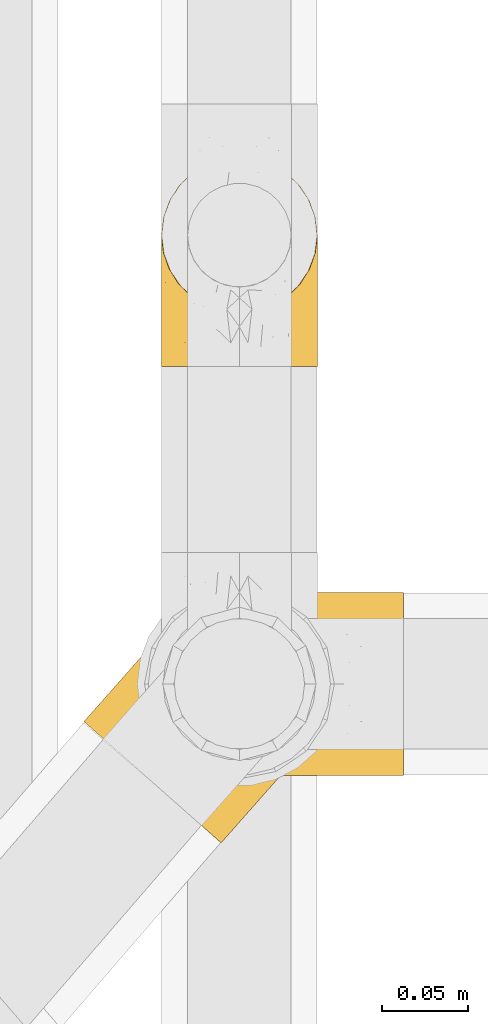
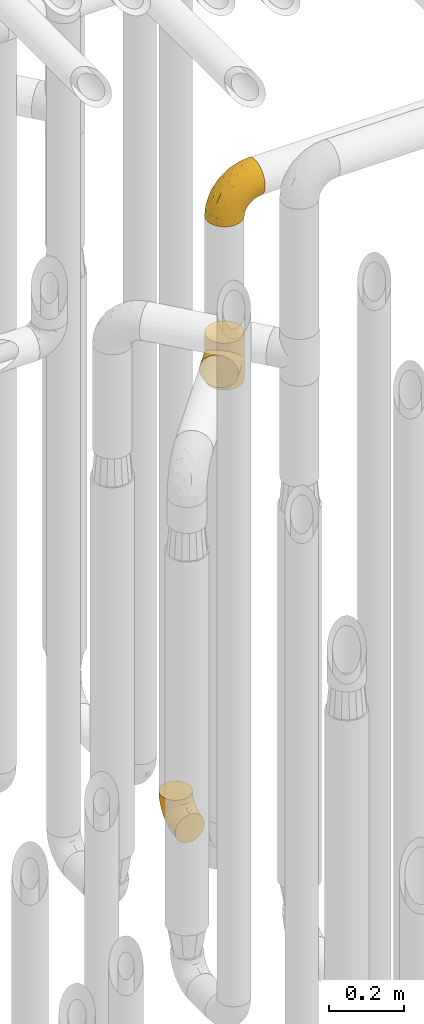
# One storey, part 219 of 827: 3 coverings.
"""IFC2X3 building model written with IfcOpenShell, lengths in millimetres."""

from ifc_helpers import new_model, entity, si_unit, converted_unit, derived_unit, direction, frame, origin, place, context, subcontext, project, spatial, faceted_brep, element, save


model = new_model("IFC2X3")

# Units and contexts
model_context = context("Model", 3, precision=0.01, world=origin(), true_north=direction((6.12303176911189e-17, 1.0)))
body_context = subcontext(model_context, "Body", "Model", "MODEL_VIEW")
ifc_project = project(units=[si_unit("LENGTHUNIT", "METRE", prefix="MILLI"), si_unit("AREAUNIT", "SQUARE_METRE"), si_unit("VOLUMEUNIT", "CUBIC_METRE"), converted_unit("PLANEANGLEUNIT", "DEGREE", entity("IfcRatioMeasure", 0.0174532925199433), si_unit("PLANEANGLEUNIT", "RADIAN"), dimensions=[0, 0, 0, 0, 0, 0, 0]), si_unit("MASSUNIT", "GRAM", prefix="KILO"), derived_unit("MASSDENSITYUNIT", [(si_unit("MASSUNIT", "GRAM", prefix="KILO"), 1), (si_unit("LENGTHUNIT", "METRE"), -3)]), derived_unit("MOMENTOFINERTIAUNIT", [(si_unit("LENGTHUNIT", "METRE"), 4)]), si_unit("TIMEUNIT", "SECOND"), si_unit("FREQUENCYUNIT", "HERTZ"), si_unit("THERMODYNAMICTEMPERATUREUNIT", "DEGREE_CELSIUS"), derived_unit("THERMALTRANSMITTANCEUNIT", [(si_unit("MASSUNIT", "GRAM", prefix="KILO"), 1), (si_unit("THERMODYNAMICTEMPERATUREUNIT", "KELVIN"), -1), (si_unit("TIMEUNIT", "SECOND"), -3)]), derived_unit("VOLUMETRICFLOWRATEUNIT", [(si_unit("LENGTHUNIT", "METRE"), 3), (si_unit("TIMEUNIT", "SECOND"), -1)]), derived_unit("MASSFLOWRATEUNIT", [(si_unit("MASSUNIT", "GRAM", prefix="KILO"), 1), (si_unit("TIMEUNIT", "SECOND"), -1)]), derived_unit("ROTATIONALFREQUENCYUNIT", [(si_unit("TIMEUNIT", "SECOND"), -1)]), si_unit("ELECTRICCURRENTUNIT", "AMPERE"), si_unit("ELECTRICVOLTAGEUNIT", "VOLT"), si_unit("POWERUNIT", "WATT"), si_unit("FORCEUNIT", "NEWTON", prefix="KILO"), si_unit("ILLUMINANCEUNIT", "LUX"), si_unit("LUMINOUSFLUXUNIT", "LUMEN"), si_unit("LUMINOUSINTENSITYUNIT", "CANDELA"), derived_unit("USERDEFINED", [(si_unit("MASSUNIT", "GRAM", prefix="KILO"), -1), (si_unit("LENGTHUNIT", "METRE"), -2), (si_unit("TIMEUNIT", "SECOND"), 3), (si_unit("LUMINOUSFLUXUNIT", "LUMEN"), 1)]), derived_unit("LINEARVELOCITYUNIT", [(si_unit("LENGTHUNIT", "METRE"), 1), (si_unit("TIMEUNIT", "SECOND"), -1)]), si_unit("PRESSUREUNIT", "PASCAL"), derived_unit("USERDEFINED", [(si_unit("LENGTHUNIT", "METRE"), -2), (si_unit("MASSUNIT", "GRAM", prefix="KILO"), 1), (si_unit("TIMEUNIT", "SECOND"), -2)]), derived_unit("LINEARFORCEUNIT", [(si_unit("MASSUNIT", "GRAM", prefix="KILO"), 1), (si_unit("LENGTHUNIT", "METRE"), 1), (si_unit("TIMEUNIT", "SECOND"), -2), (si_unit("LENGTHUNIT", "METRE"), -1)]), derived_unit("PLANARFORCEUNIT", [(si_unit("MASSUNIT", "GRAM", prefix="KILO"), 1), (si_unit("LENGTHUNIT", "METRE"), 1), (si_unit("TIMEUNIT", "SECOND"), -2), (si_unit("LENGTHUNIT", "METRE"), -2)])], contexts=[model_context])

# Site, building, storey
site_placement = place(None, origin())
site = spatial("IfcSite", under=ifc_project, at=site_placement, CompositionType="ELEMENT")
building_placement = place(site_placement, origin())
building = spatial("IfcBuilding", under=site, at=building_placement, CompositionType="ELEMENT")
storey_placement = place(building_placement, frame((0.0, 0.0, 28200.0)))
storey = spatial("IfcBuildingStorey", under=building, at=storey_placement, Name="08", CompositionType="ELEMENT", Elevation=28200.0)

# Coverings
covering_1_placement = place(storey_placement, frame((36928.29, 11912.61, 353.25)))
element("IfcCovering", 1, at=covering_1_placement, inside=storey, Name=":ADSK_", ObjectType=":ADSK_", PredefinedType="INSULATION", context=body_context, shape_type="Brep", body=[
    faceted_brep([(90.76, 87.65, 122.75), (87.42, 97.19, 122.75), (82.04, 105.75, 122.75), (74.89, 112.9, 122.75), (66.33, 118.28, 122.75), (56.79, 121.61, 122.75), (46.75, 122.75, 122.75), (36.69, 121.61, 122.75), (27.15, 118.27, 122.75), (18.59, 112.89, 122.75), (11.44, 105.74, 122.75), (6.06, 97.18, 122.75), (2.73, 87.64, 122.75), (1.6, 77.6, 122.75), (2.73, 67.54, 122.75), (6.07, 58.0, 122.75), (11.45, 49.44, 122.75), (18.6, 42.29, 122.75), (27.16, 36.91, 122.75), (36.7, 33.58, 122.75), (46.75, 32.45, 122.75), (56.8, 33.58, 122.75), (66.34, 36.92, 122.75), (74.9, 42.3, 122.75), (82.05, 49.45, 122.75), (87.43, 58.01, 122.75), (90.76, 67.55, 122.75), (91.9, 77.6, 122.75), (35.06, 1.6, 90.36), (24.17, 1.6, 85.85), (14.82, 1.6, 78.67), (7.64, 1.6, 69.32), (3.13, 1.6, 58.43), (1.6, 1.6, 46.75), (3.13, 1.6, 35.06), (7.64, 1.6, 24.17), (14.82, 1.6, 14.82), (24.17, 1.6, 7.64), (35.06, 1.6, 3.13), (46.75, 1.6, 1.6), (58.43, 1.6, 3.13), (69.32, 1.6, 7.64), (78.67, 1.6, 14.82), (85.85, 1.6, 24.17), (90.36, 1.6, 35.06), (91.9, 1.6, 46.75), (90.36, 1.6, 58.43), (85.85, 1.6, 69.32), (78.67, 1.6, 78.67), (69.32, 1.6, 85.85), (58.43, 1.6, 90.36), (46.75, 1.6, 91.9), (46.75, 99.61, 51.54), (55.2, 95.26, 47.17), (46.75, 86.21, 38.13), (46.75, 39.03, 7.52), (54.53, 30.75, 5.85), (46.75, 23.8, 5.11), (59.63, 60.8, 19.2), (62.07, 85.37, 38.98), (71.86, 73.64, 35.02), (62.65, 31.01, 8.21), (71.33, 49.14, 19.28), (72.93, 23.88, 12.19), (91.2, 82.74, 101.39), (86.31, 43.48, 34.43), (80.89, 29.47, 20.95), (79.49, 56.38, 30.74), (90.68, 72.18, 72.93), (86.84, 72.24, 56.64), (87.38, 87.6, 80.81), (76.87, 107.24, 93.43), (83.73, 101.1, 100.76), (81.03, 95.16, 74.27), (91.9, 71.81, 93.66), (91.9, 63.57, 81.33), (91.9, 55.34, 69.01), (91.03, 23.66, 40.87), (87.58, 20.55, 29.38), (56.52, 107.97, 67.05), (46.75, 116.82, 85.31), (60.4, 117.03, 93.68), (91.9, 30.68, 52.53), (91.9, 21.51, 50.71), (91.9, 12.33, 48.88), (67.87, 106.17, 72.77), (90.35, 52.37, 51.21), (69.57, 114.51, 101.18), (46.75, 119.23, 100.54), (79.91, 78.37, 48.74), (91.9, 75.46, 112.01), (91.9, 73.63, 102.83), (74.99, 101.51, 73.88), (46.75, 72.81, 24.73), (91.9, 43.01, 60.77), (88.53, 92.6, 103.08), (72.65, 91.86, 54.8), (46.75, 55.92, 16.13), (62.97, 99.01, 55.92), (46.75, 108.21, 68.42), (66.2, 32.05, 104.98), (56.6, 30.22, 108.58), (59.89, 23.37, 98.21), (90.95, 28.43, 61.56), (90.22, 16.44, 60.69), (76.64, 37.1, 100.0), (71.58, 28.88, 95.88), (79.99, 33.93, 90.81), (89.54, 50.17, 84.88), (89.97, 40.57, 73.29), (81.32, 47.62, 113.4), (74.56, 39.9, 109.8), (84.15, 47.92, 102.13), (90.37, 34.27, 67.29), (87.82, 24.65, 70.34), (90.98, 62.6, 95.15), (90.96, 66.18, 105.49), (85.14, 11.74, 71.5), (58.11, 13.89, 92.87), (46.75, 17.02, 96.03), (78.39, 15.86, 81.34), (88.22, 57.71, 107.44), (66.06, 9.11, 88.36), (68.6, 18.55, 90.43), (63.78, 34.74, 114.37), (88.42, 54.95, 98.41), (90.61, 57.35, 88.73), (83.8, 22.03, 76.89), (77.98, 24.8, 86.08), (91.22, 69.07, 112.64), (83.46, 42.31, 94.21), (46.75, 29.63, 112.22), (46.75, 28.31, 107.32), (84.66, 30.23, 79.95), (86.33, 40.13, 84.51), (46.75, 22.67, 101.67), (46.75, 12.12, 94.71), (15.1, 15.86, 81.34), (9.69, 22.03, 76.89), (15.52, 24.8, 86.08), (8.83, 30.23, 79.96), (35.39, 13.88, 92.87), (12.18, 47.61, 113.41), (1.6, 73.63, 102.83), (2.53, 66.17, 105.5), (2.27, 69.07, 112.64), (36.9, 30.22, 108.58), (27.31, 32.04, 104.98), (33.62, 23.36, 98.2), (5.07, 54.93, 98.4), (9.36, 47.91, 102.13), (5.27, 57.69, 107.44), (27.43, 9.1, 88.36), (1.6, 21.51, 50.71), (1.6, 12.33, 48.88), (10.05, 42.29, 94.22), (16.87, 37.09, 100.01), (8.35, 11.74, 71.5), (3.27, 16.44, 60.69), (1.6, 30.68, 52.53), (21.94, 28.86, 95.89), (29.72, 34.74, 114.37), (1.6, 63.57, 81.33), (1.6, 55.34, 69.01), (3.96, 50.17, 84.88), (1.6, 75.46, 112.01), (18.95, 39.89, 109.8), (2.54, 28.43, 61.56), (3.12, 34.27, 67.29), (1.6, 43.01, 60.77), (2.51, 62.59, 95.14), (3.52, 40.57, 73.29), (7.17, 40.13, 84.53), (1.6, 71.81, 93.66), (13.52, 33.92, 90.82), (2.88, 57.34, 88.73), (5.67, 24.65, 70.34), (24.89, 18.54, 90.43), (12.6, 29.47, 20.95), (7.18, 43.48, 34.43), (14.0, 56.4, 30.74), (22.16, 49.17, 19.29), (21.61, 73.69, 35.07), (3.14, 52.37, 51.21), (6.65, 72.26, 56.67), (20.82, 91.88, 54.85), (31.41, 85.36, 38.98), (5.91, 20.55, 29.38), (2.46, 23.66, 40.87), (33.87, 60.8, 19.2), (30.84, 31.02, 8.21), (38.96, 30.75, 5.85), (20.56, 23.9, 12.19), (2.81, 72.17, 72.93), (6.1, 87.59, 80.83), (2.29, 82.74, 101.39), (33.08, 117.03, 93.69), (16.61, 107.23, 93.43), (36.96, 107.97, 67.04), (9.75, 101.08, 100.76), (25.61, 106.17, 72.78), (30.5, 99.01, 55.93), (23.91, 114.5, 101.18), (12.45, 95.15, 74.27), (18.49, 101.5, 73.89), (4.96, 92.59, 103.09), (13.56, 78.38, 48.78), (38.28, 95.27, 47.19)], [[[0, 1, 2, 3, 4, 5, 6, 7, 8, 9, 10, 11, 12, 13, 14, 15, 16, 17, 18, 19, 20, 21, 22, 23, 24, 25, 26, 27]], [[28, 29, 30, 31, 32, 33, 34, 35, 36, 37, 38, 39, 40, 41, 42, 43, 44, 45, 46, 47, 48, 49, 50, 51]], [[52, 53, 54]], [[55, 56, 57]], [[58, 59, 60]], [[61, 62, 63]], [[27, 64, 0]], [[65, 66, 67]], [[41, 40, 61]], [[68, 69, 70]], [[66, 43, 42]], [[63, 42, 41]], [[71, 72, 73]], [[72, 2, 1]], [[68, 74, 75, 76]], [[45, 44, 77]], [[43, 78, 44]], [[79, 80, 81]], [[77, 82, 83, 84, 45]], [[79, 81, 85]], [[71, 2, 72]], [[65, 86, 77]], [[4, 81, 5]], [[66, 65, 78]], [[4, 3, 87]], [[81, 88, 5]], [[63, 66, 42]], [[68, 70, 64]], [[67, 60, 89]], [[71, 3, 2]], [[64, 27, 90, 91, 74]], [[92, 71, 73]], [[40, 57, 56]], [[59, 93, 54]], [[86, 76, 94, 82]], [[1, 0, 95]], [[58, 62, 61]], [[60, 96, 89]], [[85, 81, 87]], [[56, 97, 58]], [[65, 67, 69]], [[87, 81, 4]], [[67, 89, 69]], [[61, 63, 41]], [[95, 72, 1]], [[73, 72, 70]], [[69, 73, 70]], [[73, 89, 96]], [[3, 71, 87]], [[85, 87, 71]], [[58, 61, 56]], [[59, 58, 93]], [[76, 86, 68]], [[69, 89, 73]], [[68, 86, 69]], [[65, 69, 86]], [[68, 64, 74]], [[95, 64, 70]], [[98, 79, 85]], [[79, 52, 99, 80]], [[66, 62, 67]], [[62, 58, 60]], [[62, 60, 67]], [[59, 98, 96]], [[59, 96, 60]], [[96, 85, 92]], [[88, 81, 80]], [[88, 6, 5]], [[66, 63, 62]], [[64, 95, 0]], [[72, 95, 70]], [[77, 44, 78]], [[86, 82, 77]], [[40, 39, 57]], [[96, 98, 85]], [[40, 56, 61]], [[66, 78, 43]], [[77, 78, 65]], [[79, 98, 53]], [[96, 92, 73]], [[85, 71, 92]], [[97, 56, 55]], [[97, 93, 58]], [[53, 98, 59]], [[54, 53, 59]], [[79, 53, 52]], [[100, 101, 102]], [[46, 45, 84, 83]], [[103, 104, 82]], [[82, 104, 83]], [[105, 106, 107]], [[108, 109, 76]], [[110, 111, 112]], [[103, 113, 114]], [[115, 74, 116]], [[48, 47, 117]], [[118, 102, 119]], [[49, 48, 120]], [[74, 91, 116]], [[116, 121, 115]], [[49, 122, 50]], [[123, 106, 102]], [[124, 111, 22]], [[125, 126, 115]], [[23, 22, 111]], [[24, 110, 121]], [[120, 127, 128]], [[90, 26, 129]], [[27, 26, 90]], [[121, 125, 115]], [[24, 121, 25]], [[130, 105, 107]], [[129, 25, 116]], [[21, 20, 131]], [[120, 123, 122]], [[112, 105, 130]], [[50, 118, 51]], [[21, 124, 22]], [[101, 131, 132]], [[117, 120, 48]], [[24, 23, 110]], [[127, 114, 133]], [[75, 108, 76]], [[107, 134, 130]], [[133, 114, 113]], [[129, 116, 91]], [[25, 121, 116]], [[121, 112, 125]], [[75, 74, 115]], [[101, 135, 102]], [[131, 101, 21]], [[101, 100, 124]], [[128, 127, 133]], [[119, 136, 51, 118]], [[104, 47, 46]], [[83, 104, 46]], [[117, 104, 114]], [[101, 124, 21]], [[111, 124, 100]], [[102, 118, 123]], [[133, 134, 107]], [[111, 110, 23]], [[114, 104, 103]], [[94, 76, 109]], [[121, 110, 112]], [[122, 118, 50]], [[134, 109, 108]], [[133, 107, 128]], [[112, 108, 125]], [[126, 125, 108]], [[108, 75, 126]], [[75, 115, 126]], [[109, 134, 133]], [[130, 108, 112]], [[108, 130, 134]], [[105, 112, 111]], [[111, 100, 105]], [[106, 105, 100]], [[102, 106, 100]], [[128, 106, 123]], [[90, 129, 91]], [[25, 129, 26]], [[104, 117, 47]], [[117, 114, 127]], [[82, 94, 103]], [[113, 94, 109]], [[94, 113, 103]], [[133, 113, 109]], [[106, 128, 107]], [[123, 120, 128]], [[120, 122, 49]], [[118, 122, 123]], [[135, 101, 132]], [[135, 119, 102]], [[117, 127, 120]], [[30, 29, 137]], [[138, 139, 140]], [[51, 136, 119, 141]], [[142, 17, 16]], [[143, 144, 145]], [[146, 147, 148]], [[149, 150, 151]], [[152, 29, 28]], [[33, 32, 153, 154]], [[150, 155, 156]], [[157, 31, 30]], [[153, 158, 159]], [[29, 152, 137]], [[148, 141, 119]], [[156, 160, 147]], [[148, 135, 146]], [[137, 138, 157]], [[19, 161, 146]], [[162, 163, 164]], [[14, 13, 165]], [[153, 32, 158]], [[147, 161, 166]], [[18, 17, 166]], [[167, 168, 169]], [[166, 150, 156]], [[151, 150, 142]], [[151, 170, 149]], [[151, 16, 15]], [[171, 140, 172]], [[165, 143, 145]], [[173, 170, 144]], [[142, 166, 17]], [[19, 131, 20]], [[144, 170, 151]], [[18, 161, 19]], [[173, 144, 143]], [[140, 139, 174]], [[171, 164, 163]], [[164, 172, 155]], [[151, 15, 144]], [[145, 15, 14]], [[173, 162, 170]], [[149, 175, 164]], [[19, 146, 131]], [[132, 131, 146]], [[160, 148, 147]], [[159, 158, 167]], [[135, 132, 146]], [[158, 32, 31]], [[157, 158, 31]], [[167, 158, 176]], [[166, 161, 18]], [[146, 161, 147]], [[148, 177, 141]], [[171, 168, 140]], [[171, 163, 169]], [[151, 142, 16]], [[166, 142, 150]], [[152, 141, 177]], [[51, 141, 28]], [[138, 140, 176]], [[172, 140, 174]], [[175, 149, 170]], [[164, 150, 149]], [[170, 162, 175]], [[162, 164, 175]], [[155, 172, 174]], [[171, 172, 164]], [[155, 174, 156]], [[164, 155, 150]], [[160, 156, 174]], [[147, 166, 156]], [[139, 160, 174]], [[148, 160, 177]], [[15, 145, 144]], [[165, 145, 14]], [[137, 157, 30]], [[158, 157, 176]], [[168, 167, 176]], [[169, 159, 167]], [[140, 168, 176]], [[169, 168, 171]], [[137, 177, 139]], [[160, 139, 177]], [[141, 152, 28]], [[137, 152, 177]], [[148, 119, 135]], [[157, 138, 176]], [[139, 138, 137]], [[178, 179, 180]], [[181, 180, 182]], [[179, 183, 184]], [[185, 186, 182]], [[187, 188, 179]], [[188, 33, 154, 153, 159]], [[181, 189, 190]], [[35, 34, 187]], [[191, 38, 190]], [[192, 178, 181]], [[179, 184, 180]], [[192, 190, 37]], [[37, 190, 38]], [[36, 35, 178]], [[54, 93, 186]], [[35, 187, 178]], [[193, 194, 184]], [[195, 173, 143, 165, 13]], [[195, 193, 173]], [[193, 163, 162, 173]], [[13, 12, 195]], [[8, 7, 196]], [[9, 197, 10]], [[198, 80, 99, 52]], [[196, 7, 88]], [[197, 199, 10]], [[182, 189, 181]], [[200, 198, 201]], [[200, 196, 198]], [[9, 8, 202]], [[194, 199, 203]], [[192, 37, 36]], [[80, 196, 88]], [[183, 159, 169, 163]], [[188, 34, 33]], [[202, 200, 197]], [[185, 203, 204]], [[202, 8, 196]], [[10, 199, 11]], [[12, 11, 205]], [[38, 191, 57]], [[189, 97, 191]], [[203, 199, 197]], [[205, 199, 194]], [[204, 203, 197]], [[184, 203, 206]], [[200, 202, 196]], [[197, 9, 202]], [[207, 54, 186]], [[97, 55, 191]], [[194, 203, 184]], [[183, 163, 193]], [[184, 206, 180]], [[183, 193, 184]], [[205, 195, 12]], [[193, 195, 194]], [[80, 198, 196]], [[207, 186, 201]], [[182, 180, 206]], [[181, 178, 180]], [[185, 182, 206]], [[182, 186, 189]], [[203, 185, 206]], [[185, 200, 201]], [[7, 6, 88]], [[178, 192, 36]], [[190, 192, 181]], [[199, 205, 11]], [[195, 205, 194]], [[159, 183, 188]], [[179, 188, 183]], [[57, 191, 55]], [[57, 39, 38]], [[189, 191, 190]], [[188, 187, 34]], [[178, 187, 179]], [[186, 93, 189]], [[197, 200, 204]], [[185, 204, 200]], [[189, 93, 97]], [[207, 198, 52]], [[185, 201, 186]], [[198, 207, 201]], [[54, 207, 52]]]),
])
covering_2_placement = place(storey_placement, frame((36883.36, 11636.53, 1974.0)))
element("IfcCovering", 2, at=covering_2_placement, inside=storey, Name=":ADSK_", ObjectType=":ADSK_", PredefinedType="INSULATION", context=body_context, shape_type="Brep", body=[
    faceted_brep([(47.55, 123.13, 68.86), (51.92, 128.8, 0.0), (44.18, 117.32, 0.0), (39.68, 104.22, 0.0), (41.21, 110.03, 54.84), (38.64, 94.84, 41.76), (38.72, 90.4, 0.0), (39.39, 102.67, 48.13), (51.92, 128.8, 76.0), (47.55, 123.13, 83.14), (51.92, 128.8, 152.0), (43.96, 116.86, 61.78), (39.1, 86.61, 35.89), (41.37, 76.81, 0.0), (44.45, 69.5, 26.62), (44.41, 70.59, 0.0), (47.45, 64.37, 0.0), (52.0, 59.14, 0.0), (56.55, 53.92, 0.0), (56.55, 53.92, 22.95), (52.0, 59.14, 152.0), (56.55, 53.92, 129.05), (56.55, 53.92, 152.0), (40.97, 78.08, 30.74), (49.67, 61.27, 23.9), (65.65, 47.44, 24.13), (65.65, 47.44, 127.87), (68.03, 46.18, 0.0), (75.5, 43.15, 27.43), (74.58, 43.93, 0.0), (81.13, 41.68, 0.0), (94.94, 40.73, 0.0), (94.85, 40.72, 38.42), (85.38, 41.0, 32.36), (103.7, 42.01, 45.24), (108.54, 43.38, 0.0), (111.82, 44.6, 52.57), (120.98, 49.46, 0.0), (125.73, 53.0, 68.06), (131.43, 58.55, 0.0), (119.18, 48.31, 60.22), (131.43, 58.55, 76.0), (125.73, 53.0, 83.94), (131.43, 58.55, 152.0), (135.89, 122.98, 152.0), (126.8, 133.43, 152.0), (115.31, 141.17, 152.0), (102.22, 145.67, 152.0), (88.4, 146.62, 152.0), (74.81, 143.97, 152.0), (62.36, 137.89, 152.0), (44.18, 117.32, 152.0), (39.68, 104.22, 152.0), (38.72, 90.4, 152.0), (41.37, 76.81, 152.0), (44.41, 70.59, 152.0), (47.45, 64.37, 152.0), (68.03, 46.18, 152.0), (74.58, 43.93, 152.0), (81.13, 41.68, 152.0), (94.94, 40.73, 152.0), (108.54, 43.38, 152.0), (120.98, 49.46, 152.0), (139.16, 70.03, 152.0), (143.66, 83.13, 152.0), (144.62, 96.95, 152.0), (141.97, 110.54, 152.0), (62.36, 137.89, 0.0), (74.81, 143.97, 0.0), (88.4, 146.62, 0.0), (102.22, 145.67, 0.0), (115.31, 141.17, 0.0), (126.8, 133.43, 0.0), (135.89, 122.98, 0.0), (141.97, 110.54, 0.0), (144.62, 96.95, 0.0), (143.66, 83.13, 0.0), (139.16, 70.03, 0.0), (43.96, 116.86, 90.22), (41.21, 110.03, 97.16), (39.39, 102.67, 103.87), (38.64, 94.84, 110.24), (39.1, 86.61, 116.11), (40.97, 78.08, 121.26), (44.45, 69.5, 125.38), (49.67, 61.27, 128.1), (75.5, 43.15, 124.57), (85.38, 41.0, 119.64), (94.85, 40.72, 113.58), (111.82, 44.6, 99.43), (119.18, 48.31, 91.78), (103.7, 42.01, 106.76), (1.6, 71.85, 76.0), (2.95, 70.65, 62.27), (6.92, 67.14, 49.47), (13.24, 61.56, 38.49), (21.47, 54.29, 30.06), (26.27, 50.05, 27.41), (31.06, 45.81, 24.76), (36.21, 41.27, 23.85), (41.35, 36.72, 22.95), (51.64, 27.63, 24.76), (56.43, 23.39, 27.41), (61.23, 19.16, 30.06), (69.46, 11.88, 38.49), (75.78, 6.3, 49.47), (79.75, 2.79, 62.27), (81.1, 1.6, 76.0), (79.75, 2.79, 89.73), (75.78, 6.3, 102.53), (69.46, 11.88, 113.51), (61.23, 19.16, 121.94), (56.43, 23.39, 124.59), (51.64, 27.63, 127.24), (41.35, 36.72, 129.05), (36.21, 41.27, 128.15), (31.06, 45.81, 127.24), (26.27, 50.05, 124.59), (21.47, 54.29, 121.94), (13.24, 61.56, 113.51), (6.92, 67.14, 102.53), (2.95, 70.65, 89.73)], [[[0, 1, 2]], [[2, 3, 4]], [[5, 3, 6]], [[5, 7, 3]], [[0, 8, 1]], [[8, 9, 10]], [[4, 11, 2]], [[7, 4, 3]], [[0, 2, 11]], [[12, 6, 13]], [[14, 13, 15, 16]], [[17, 18, 19]], [[20, 21, 22]], [[23, 12, 13]], [[24, 14, 16]], [[24, 17, 19]], [[24, 16, 17]], [[23, 13, 14]], [[6, 12, 5]], [[25, 19, 18]], [[21, 26, 22]], [[25, 18, 27]], [[28, 27, 29, 30]], [[28, 25, 27]], [[31, 32, 33]], [[28, 30, 33]], [[33, 30, 31]], [[34, 31, 35]], [[36, 35, 37]], [[38, 37, 39]], [[36, 34, 35]], [[38, 40, 37]], [[41, 38, 39]], [[42, 41, 43]], [[36, 37, 40]], [[31, 34, 32]], [[44, 45, 46, 47, 48, 49, 50, 10, 51, 52, 53, 54, 55, 56, 20, 22, 57, 58, 59, 60, 61, 62, 43, 63, 64, 65, 66]], [[1, 67, 68, 69, 70, 71, 72, 73, 74, 75, 76, 77, 39, 37, 35, 31, 30, 29, 27, 18, 17, 16, 15, 13, 6, 3, 2]], [[70, 69, 48, 47]], [[45, 72, 71, 46]], [[46, 71, 70, 47]], [[49, 68, 67, 50]], [[1, 8, 10, 50, 67]], [[48, 69, 68, 49]], [[78, 79, 51]], [[9, 78, 51]], [[10, 9, 51]], [[52, 80, 81]], [[52, 51, 79]], [[52, 81, 53]], [[80, 52, 79]], [[82, 83, 54]], [[84, 56, 55, 54]], [[84, 85, 56]], [[21, 20, 85]], [[83, 84, 54]], [[53, 82, 54]], [[85, 20, 56]], [[82, 53, 81]], [[26, 86, 57]], [[59, 87, 60]], [[86, 59, 58, 57]], [[86, 87, 59]], [[22, 26, 57]], [[87, 88, 60]], [[89, 90, 62]], [[90, 42, 62]], [[60, 91, 61]], [[91, 60, 88]], [[89, 61, 91]], [[89, 62, 61]], [[42, 43, 62]], [[41, 39, 77, 63, 43]], [[63, 77, 76, 64]], [[76, 75, 65, 64]], [[65, 75, 74, 66]], [[66, 74, 73, 44]], [[44, 73, 72, 45]], [[92, 93, 94, 95, 96, 97, 98, 99, 100, 101, 102, 103, 104, 105, 106, 107, 108, 109, 110, 111, 112, 113, 114, 115, 116, 117, 118, 119, 120, 121]], [[24, 99, 98]], [[96, 95, 12]], [[14, 98, 97, 96]], [[19, 99, 24]], [[19, 100, 99]], [[23, 14, 96]], [[12, 23, 96]], [[24, 98, 14]], [[95, 5, 12]], [[7, 5, 94]], [[94, 5, 95]], [[4, 94, 93]], [[0, 93, 92]], [[4, 7, 94]], [[0, 11, 93]], [[8, 0, 92]], [[4, 93, 11]], [[9, 92, 121]], [[121, 120, 79]], [[81, 120, 119]], [[81, 80, 120]], [[9, 8, 92]], [[79, 78, 121]], [[80, 79, 120]], [[9, 121, 78]], [[82, 119, 118]], [[84, 118, 117, 116]], [[115, 114, 21]], [[83, 82, 118]], [[85, 84, 116]], [[85, 115, 21]], [[85, 116, 115]], [[83, 118, 84]], [[119, 82, 81]], [[26, 21, 114]], [[26, 114, 113]], [[86, 113, 112, 111]], [[86, 26, 113]], [[110, 88, 87]], [[86, 111, 87]], [[87, 111, 110]], [[91, 110, 109]], [[89, 109, 108]], [[42, 108, 107]], [[89, 91, 109]], [[42, 90, 108]], [[41, 42, 107]], [[89, 108, 90]], [[110, 91, 88]], [[38, 107, 106]], [[106, 105, 36]], [[34, 105, 104]], [[34, 36, 105]], [[38, 41, 107]], [[36, 40, 106]], [[38, 106, 40]], [[33, 104, 103]], [[28, 103, 102, 101]], [[25, 101, 100]], [[33, 32, 104]], [[25, 28, 101]], [[19, 25, 100]], [[33, 103, 28]], [[104, 32, 34]]]),
])
covering_3_placement = place(storey_placement, frame((36920.39, 11675.56, 2503.4)))
element("IfcCovering", 3, at=covering_3_placement, inside=storey, Name=":ADSK_", ObjectType=":ADSK_", PredefinedType="INSULATION", context=body_context, shape_type="Brep", body=[
    faceted_brep([(149.65, 66.44, 148.32), (149.65, 54.65, 149.65), (149.65, 42.84, 148.31), (149.65, 31.62, 144.39), (149.65, 21.56, 138.06), (149.65, 13.16, 129.66), (149.65, 6.84, 119.6), (149.65, 2.92, 108.39), (149.65, 1.6, 96.6), (149.65, 2.93, 84.79), (149.65, 6.85, 73.57), (149.65, 13.18, 63.51), (149.65, 21.58, 55.11), (149.65, 31.64, 48.79), (149.65, 42.85, 44.87), (149.65, 54.65, 43.55), (149.65, 66.46, 44.88), (149.65, 77.67, 48.8), (149.65, 87.73, 55.13), (149.65, 96.13, 63.53), (149.65, 102.45, 73.59), (149.65, 106.37, 84.8), (149.65, 107.7, 96.6), (149.65, 106.36, 108.41), (149.65, 102.44, 119.62), (149.65, 96.11, 129.68), (149.65, 87.71, 138.08), (149.65, 77.65, 144.4), (105.89, 40.91, 1.6), (100.59, 28.12, 1.6), (92.16, 17.13, 1.6), (81.17, 8.7, 1.6), (68.38, 3.4, 1.6), (54.65, 1.6, 1.6), (40.91, 3.4, 1.6), (28.12, 8.7, 1.6), (17.13, 17.13, 1.6), (8.7, 28.12, 1.6), (3.4, 40.91, 1.6), (1.6, 54.65, 1.6), (3.4, 68.38, 1.6), (8.7, 81.17, 1.6), (17.13, 92.16, 1.6), (28.12, 100.59, 1.6), (40.91, 105.89, 1.6), (54.65, 107.7, 1.6), (68.38, 105.89, 1.6), (81.17, 100.59, 1.6), (92.16, 92.16, 1.6), (100.59, 81.17, 1.6), (105.89, 68.38, 1.6), (107.7, 54.65, 1.6), (14.05, 85.53, 27.97), (9.45, 73.42, 37.09), (22.36, 83.77, 58.27), (4.7, 64.22, 27.13), (6.64, 54.65, 39.91), (81.47, 96.72, 109.11), (56.83, 93.36, 94.41), (64.02, 84.47, 110.94), (34.04, 71.37, 89.69), (21.43, 54.65, 75.62), (44.96, 54.65, 106.28), (49.8, 103.47, 60.12), (35.43, 100.91, 41.41), (42.1, 99.1, 63.22), (43.59, 105.43, 32.05), (57.88, 106.79, 52.13), (91.8, 89.81, 123.27), (88.01, 79.59, 129.32), (115.65, 81.29, 138.3), (18.94, 74.01, 62.95), (12.83, 64.14, 55.89), (24.96, 94.75, 37.4), (111.33, 54.65, 144.6), (113.8, 70.74, 142.66), (60.89, 68.3, 117.85), (86.24, 66.05, 134.01), (65.84, 100.73, 89.25), (124.58, 106.78, 103.34), (121.36, 103.6, 113.52), (72.79, 107.7, 57.43), (66.04, 107.7, 44.19), (59.29, 107.7, 30.95), (73.26, 106.07, 77.98), (121.69, 90.59, 132.66), (109.82, 97.43, 121.52), (40.11, 84.51, 86.93), (36.57, 93.3, 68.4), (93.81, 107.7, 78.45), (83.3, 107.7, 67.94), (136.6, 107.7, 94.53), (120.29, 107.7, 91.95), (99.11, 106.79, 93.36), (107.05, 107.7, 85.2), (91.12, 103.47, 101.45), (75.62, 54.65, 129.81), (56.97, 107.7, 16.27), (126.65, 76.99, 42.46), (116.55, 84.28, 40.4), (120.09, 91.11, 49.71), (76.06, 106.26, 39.4), (83.69, 102.6, 31.26), (71.88, 106.08, 27.7), (66.92, 106.56, 16.7), (110.43, 105.36, 70.67), (121.31, 106.74, 81.69), (81.0, 101.59, 16.68), (113.32, 54.65, 22.57), (111.09, 54.65, 14.26), (109.14, 67.71, 17.68), (95.86, 91.36, 19.58), (99.07, 94.33, 33.49), (106.92, 87.1, 33.01), (131.39, 65.84, 40.69), (136.98, 54.65, 40.15), (128.67, 54.65, 37.93), (117.07, 68.92, 31.04), (96.39, 100.82, 45.29), (106.61, 79.83, 23.55), (103.72, 77.13, 11.36), (92.14, 105.9, 59.1), (107.13, 101.53, 57.42), (98.03, 106.72, 68.96), (88.38, 97.75, 20.38), (130.66, 103.08, 72.46), (135.45, 106.39, 83.66), (123.57, 98.1, 60.66), (137.75, 95.02, 61.01), (133.2, 86.9, 51.85), (138.8, 74.42, 46.07), (120.99, 54.65, 30.25), (84.53, 105.28, 46.65), (108.72, 92.87, 43.0), (95.86, 17.93, 19.58), (130.67, 6.22, 72.44), (109.13, 41.58, 17.67), (93.81, 1.6, 78.45), (98.02, 2.57, 68.97), (110.43, 3.94, 70.65), (131.4, 43.46, 40.69), (126.66, 32.32, 42.45), (117.08, 40.38, 31.04), (108.74, 16.44, 42.99), (96.31, 8.47, 45.18), (99.11, 15.01, 33.46), (123.58, 11.21, 60.64), (107.12, 7.78, 57.37), (72.79, 1.6, 57.43), (66.04, 1.6, 44.19), (76.07, 3.04, 39.35), (56.97, 1.6, 16.27), (66.92, 2.73, 16.7), (120.29, 1.6, 91.95), (107.05, 1.6, 85.2), (121.26, 2.55, 81.68), (84.46, 3.98, 46.68), (83.69, 6.69, 31.26), (81.0, 7.7, 16.68), (71.88, 3.21, 27.7), (137.76, 14.28, 60.99), (133.21, 22.42, 51.84), (116.58, 25.02, 40.41), (120.1, 18.18, 49.72), (138.81, 34.89, 46.06), (136.6, 1.6, 94.53), (103.72, 32.17, 11.35), (106.96, 22.23, 33.02), (135.44, 2.91, 83.65), (88.38, 11.54, 20.38), (83.3, 1.6, 67.94), (92.12, 3.38, 59.12), (106.6, 29.46, 23.53), (59.29, 1.6, 30.95), (22.36, 25.52, 58.27), (14.05, 23.76, 27.97), (24.96, 14.54, 37.4), (35.43, 8.38, 41.41), (4.71, 45.07, 27.21), (9.45, 35.87, 37.09), (11.79, 45.14, 53.2), (57.88, 2.5, 52.13), (124.57, 2.51, 103.34), (121.37, 5.68, 113.5), (91.12, 5.82, 101.45), (56.83, 15.93, 94.41), (81.48, 12.54, 109.08), (64.05, 24.81, 110.95), (99.11, 2.5, 93.36), (73.26, 3.22, 77.98), (43.59, 3.86, 32.05), (19.5, 35.85, 64.63), (91.8, 19.47, 123.25), (121.7, 18.68, 132.65), (88.04, 29.68, 129.32), (123.34, 27.95, 139.96), (60.89, 40.99, 117.85), (34.04, 37.92, 89.69), (109.85, 11.85, 121.51), (42.1, 10.19, 63.23), (65.78, 8.55, 89.17), (113.81, 38.53, 142.66), (36.57, 15.99, 68.4), (40.12, 24.79, 86.94), (49.8, 5.82, 60.12), (86.08, 40.56, 133.2)], [[[0, 1, 2, 3, 4, 5, 6, 7, 8, 9, 10, 11, 12, 13, 14, 15, 16, 17, 18, 19, 20, 21, 22, 23, 24, 25, 26, 27]], [[28, 29, 30, 31, 32, 33, 34, 35, 36, 37, 38, 39, 40, 41, 42, 43, 44, 45, 46, 47, 48, 49, 50, 51]], [[52, 53, 54]], [[55, 39, 56]], [[57, 58, 59]], [[60, 61, 62]], [[63, 64, 65]], [[66, 63, 67]], [[68, 69, 70]], [[53, 71, 54]], [[41, 40, 53]], [[53, 72, 71]], [[73, 42, 52]], [[42, 41, 52]], [[74, 0, 75]], [[69, 76, 77]], [[43, 73, 64]], [[45, 44, 66]], [[57, 78, 58]], [[23, 79, 80]], [[67, 81, 82, 83]], [[67, 84, 81]], [[24, 23, 80]], [[25, 85, 26]], [[86, 85, 25]], [[42, 73, 43]], [[0, 27, 75]], [[25, 24, 86]], [[70, 26, 85]], [[0, 74, 1]], [[68, 85, 86]], [[66, 64, 63]], [[60, 59, 87]], [[54, 87, 88]], [[76, 60, 62]], [[84, 89, 90, 81]], [[79, 22, 91, 92]], [[77, 74, 75]], [[93, 92, 94, 89]], [[80, 86, 24]], [[40, 55, 53]], [[76, 59, 60]], [[93, 84, 95]], [[76, 62, 96]], [[55, 72, 53]], [[70, 27, 26]], [[75, 70, 69]], [[78, 84, 63]], [[93, 79, 92]], [[95, 86, 80]], [[77, 76, 96]], [[59, 69, 68]], [[57, 68, 86]], [[68, 57, 59]], [[59, 58, 87]], [[76, 69, 59]], [[88, 87, 58]], [[87, 54, 71]], [[86, 95, 57]], [[78, 57, 95]], [[84, 78, 95]], [[78, 63, 65]], [[58, 78, 65]], [[54, 88, 73]], [[84, 93, 89]], [[79, 95, 80]], [[79, 93, 95]], [[22, 79, 23]], [[66, 83, 97, 45]], [[84, 67, 63]], [[83, 66, 67]], [[64, 44, 43]], [[64, 66, 44]], [[65, 73, 88]], [[53, 52, 41]], [[73, 52, 54]], [[73, 65, 64]], [[65, 88, 58]], [[39, 55, 40]], [[72, 55, 56]], [[56, 61, 72]], [[60, 72, 61]], [[72, 60, 71]], [[87, 71, 60]], [[27, 70, 75]], [[68, 70, 85]], [[74, 77, 96]], [[69, 77, 75]], [[98, 99, 100]], [[46, 45, 97]], [[101, 102, 103]], [[103, 104, 83]], [[105, 94, 106]], [[107, 103, 102]], [[108, 109, 51, 110]], [[111, 112, 113]], [[114, 115, 116]], [[47, 104, 107]], [[110, 117, 108]], [[49, 48, 111]], [[102, 118, 112]], [[119, 120, 111]], [[50, 49, 120]], [[121, 122, 118]], [[105, 123, 89]], [[124, 48, 107]], [[20, 19, 125]], [[121, 81, 90]], [[117, 119, 99]], [[21, 20, 126]], [[22, 21, 91]], [[105, 125, 127]], [[110, 51, 50]], [[19, 128, 125]], [[16, 15, 115]], [[129, 98, 100]], [[126, 91, 21]], [[128, 129, 127]], [[122, 123, 105]], [[114, 117, 98]], [[17, 16, 130]], [[18, 128, 19]], [[129, 18, 17]], [[125, 106, 126]], [[115, 114, 16]], [[130, 129, 17]], [[114, 98, 130]], [[117, 116, 131, 108]], [[99, 119, 113]], [[122, 121, 123]], [[92, 126, 106]], [[105, 127, 122]], [[132, 121, 118]], [[114, 130, 16]], [[129, 130, 98]], [[50, 120, 110]], [[129, 128, 18]], [[125, 128, 127]], [[125, 126, 20]], [[91, 126, 92]], [[105, 89, 94]], [[105, 106, 125]], [[94, 92, 106]], [[100, 122, 127]], [[118, 122, 133]], [[112, 118, 133]], [[132, 118, 102]], [[132, 102, 101]], [[81, 121, 132]], [[82, 103, 83]], [[132, 101, 81]], [[104, 47, 46]], [[124, 107, 102]], [[48, 47, 107]], [[113, 112, 133]], [[112, 111, 124]], [[99, 113, 133]], [[111, 113, 119]], [[99, 133, 100]], [[117, 99, 98]], [[122, 100, 133]], [[127, 129, 100]], [[103, 82, 101]], [[81, 101, 82]], [[112, 124, 102]], [[48, 124, 111]], [[104, 103, 107]], [[46, 97, 104]], [[111, 120, 49]], [[83, 104, 97]], [[110, 120, 119]], [[117, 110, 119]], [[116, 117, 114]], [[123, 90, 89]], [[90, 123, 121]], [[30, 29, 134]], [[11, 10, 135]], [[51, 109, 108, 136]], [[137, 138, 139]], [[140, 141, 142]], [[143, 144, 145]], [[146, 139, 147]], [[148, 149, 150]], [[151, 32, 152]], [[153, 154, 155]], [[156, 150, 157]], [[158, 157, 159]], [[108, 142, 136]], [[31, 158, 152]], [[160, 161, 12]], [[162, 163, 143]], [[140, 142, 116]], [[142, 141, 162]], [[14, 164, 140]], [[14, 140, 115]], [[9, 8, 165]], [[160, 12, 11]], [[141, 164, 161]], [[13, 12, 161]], [[14, 115, 15]], [[28, 166, 29]], [[135, 139, 146]], [[141, 163, 162]], [[135, 146, 160]], [[143, 167, 162]], [[29, 166, 134]], [[116, 142, 108, 131]], [[165, 153, 168]], [[10, 9, 168]], [[168, 135, 10]], [[138, 147, 139]], [[158, 169, 157]], [[14, 13, 164]], [[116, 115, 140]], [[145, 167, 143]], [[135, 160, 11]], [[168, 153, 155]], [[138, 170, 171]], [[157, 144, 156]], [[147, 144, 143]], [[161, 164, 13]], [[140, 164, 141]], [[142, 172, 136]], [[136, 172, 166]], [[161, 160, 146]], [[165, 168, 9]], [[155, 139, 135]], [[139, 154, 137]], [[168, 155, 135]], [[139, 155, 154]], [[144, 147, 171]], [[163, 147, 143]], [[156, 144, 171]], [[157, 169, 145]], [[171, 148, 156]], [[173, 159, 149]], [[159, 157, 150]], [[152, 159, 173]], [[159, 152, 158]], [[31, 30, 158]], [[169, 30, 134]], [[157, 145, 144]], [[167, 134, 172]], [[134, 167, 145]], [[172, 142, 162]], [[162, 167, 172]], [[163, 141, 161]], [[161, 146, 163]], [[147, 163, 146]], [[148, 150, 156]], [[149, 159, 150]], [[30, 169, 158]], [[145, 169, 134]], [[151, 33, 32]], [[31, 152, 32]], [[152, 173, 151]], [[28, 51, 136]], [[134, 166, 172]], [[28, 136, 166]], [[147, 138, 171]], [[170, 138, 137]], [[170, 148, 171]], [[174, 175, 176]], [[35, 34, 177]], [[178, 179, 180]], [[181, 173, 149, 148]], [[182, 183, 184]], [[185, 186, 187]], [[188, 189, 137]], [[190, 33, 151, 173]], [[191, 179, 174]], [[34, 190, 177]], [[39, 38, 178]], [[192, 193, 194]], [[4, 3, 195]], [[175, 179, 37]], [[38, 37, 179]], [[35, 176, 36]], [[196, 62, 197]], [[181, 190, 173]], [[37, 36, 175]], [[183, 6, 198]], [[189, 148, 170, 137]], [[185, 199, 200]], [[3, 2, 201]], [[202, 185, 203]], [[8, 7, 182]], [[200, 184, 186]], [[183, 7, 6]], [[181, 189, 204]], [[200, 189, 184]], [[5, 198, 6]], [[187, 203, 185]], [[195, 3, 201]], [[205, 196, 194]], [[62, 61, 197]], [[186, 198, 192]], [[180, 179, 191]], [[2, 1, 74]], [[198, 193, 192]], [[193, 5, 4]], [[194, 193, 195]], [[2, 74, 201]], [[5, 193, 198]], [[205, 74, 96]], [[188, 137, 154, 153]], [[62, 196, 96]], [[56, 178, 180]], [[198, 184, 183]], [[184, 188, 182]], [[203, 197, 191]], [[205, 194, 201]], [[187, 192, 194]], [[192, 187, 186]], [[194, 196, 187]], [[197, 187, 196]], [[197, 203, 187]], [[202, 174, 176]], [[200, 186, 185]], [[184, 198, 186]], [[199, 185, 202]], [[189, 200, 204]], [[174, 202, 203]], [[176, 177, 199]], [[189, 181, 148]], [[190, 181, 204]], [[190, 204, 177]], [[190, 34, 33]], [[188, 153, 182]], [[189, 188, 184]], [[182, 153, 165, 8]], [[183, 182, 7]], [[199, 177, 204]], [[35, 177, 176]], [[176, 175, 36]], [[179, 175, 174]], [[200, 199, 204]], [[176, 199, 202]], [[203, 191, 174]], [[180, 197, 61]], [[197, 180, 191]], [[61, 56, 180]], [[39, 178, 56]], [[38, 179, 178]], [[194, 195, 201]], [[4, 195, 193]], [[74, 205, 201]], [[96, 196, 205]]]),
])

save(model, "model.ifc")
